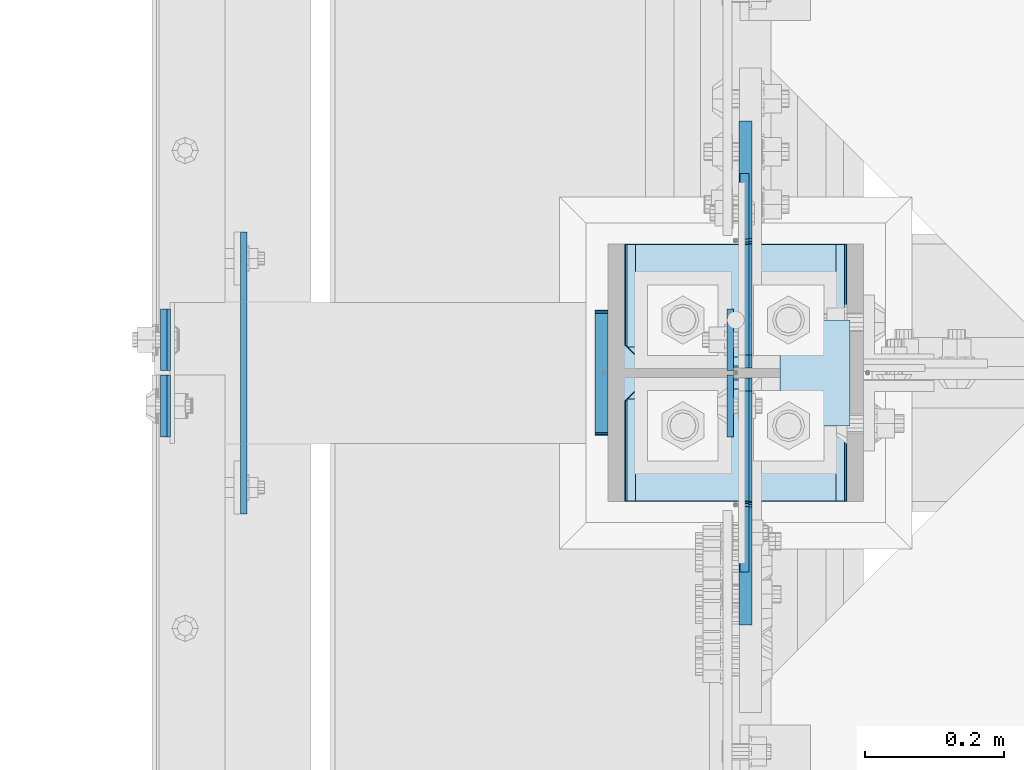
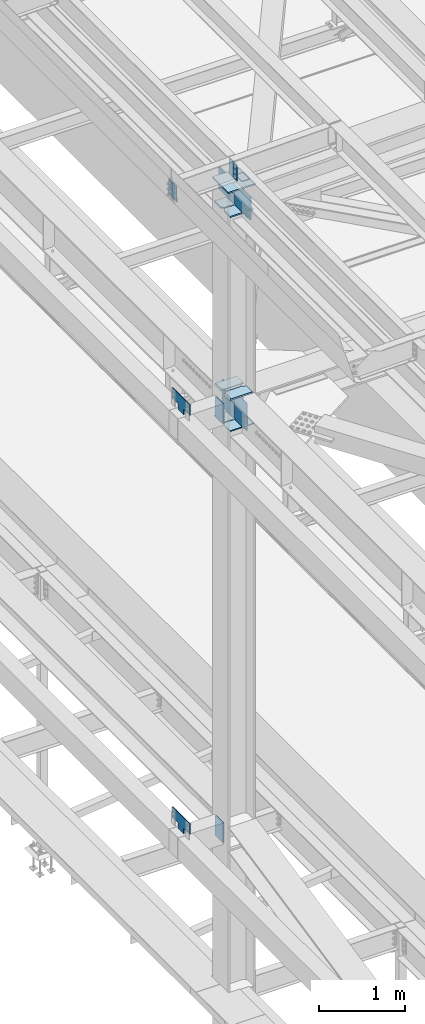
# One storey, part 3229 of 3843: 20 plates, 2 elements without a shape of their own.
"""IFC2X3 building model written with IfcOpenShell, lengths in millimetres."""

import ifcopenshell
import ifcopenshell.guid

model = None  # the IFC model being written
_history = None  # IfcOwnerHistory: only IFC2X3 demands one
_inside = {}  # id of a spatial element -> (the spatial element, [elements in it])
_under = {}  # id of a project, library or spatial element -> (it, [spatial elements below it])
_declared = {}  # id of a project -> (the project, [libraries it declares])
_typed = {}  # id of a type object -> (the type object, [elements of that type])
_made_of = {}  # id of a material, layer set ... -> (it, [elements and type objects made of it])


def new_model(schema):
    """Start an empty IFC model of exactly this schema.

    Asked for "IFC4X3", IfcOpenShell would pick the latest addendum, in which some entities
    have other attributes; the version numbers below select the first issue.
    IFC2X3 requires an IfcOwnerHistory on every rooted entity: one is made here for all.
    """
    global model, _history
    if schema == "IFC4X3":
        model = ifcopenshell.file(schema_version=(4, 3, 0, 0))
    else:
        model = ifcopenshell.file(schema=schema)
    _inside.clear()
    _under.clear()
    _declared.clear()
    _typed.clear()
    _made_of.clear()
    _history = None
    if model.schema == "IFC2X3":
        org = make("IfcOrganization", Name="unknown")
        user = make(
            "IfcPersonAndOrganization",
            ThePerson=make("IfcPerson", FamilyName="unknown"),
            TheOrganization=org,
        )
        app = make(
            "IfcApplication",
            ApplicationDeveloper=org,
            Version="unknown",
            ApplicationFullName="unknown",
            ApplicationIdentifier="unknown",
        )
        _history = make(
            "IfcOwnerHistory",
            OwningUser=user,
            OwningApplication=app,
            ChangeAction="ADDED",
            CreationDate=0,
        )
    return model


def make(cls, **values):
    """One entity of the class cls with the attributes given. An attribute that is None is left unset."""
    return model.create_entity(
        cls, **{name: value for name, value in values.items() if value is not None}
    )


def rooted(cls, **values):
    """An entity with a GlobalId (a new one), such as an element, a storey or a relation."""
    return make(cls, GlobalId=ifcopenshell.guid.new(), OwnerHistory=_history, **values)


def si_unit(unit_type, name, prefix=None):
    """IfcSIUnit, for example si_unit("LENGTHUNIT", "METRE", prefix="MILLI")."""
    return make("IfcSIUnit", UnitType=unit_type, Prefix=prefix, Name=name)


def assignment(units):
    """IfcUnitAssignment: the units of a project."""
    return None if units is None else make("IfcUnitAssignment", Units=units)


def point(xyz):
    """IfcCartesianPoint."""
    return None if xyz is None else make("IfcCartesianPoint", Coordinates=xyz)


def direction(xyz):
    """IfcDirection."""
    return None if xyz is None else make("IfcDirection", DirectionRatios=xyz)


def frame(location, z_axis=None, x_axis=None):
    """IfcAxis2Placement3D, a coordinate frame: its origin and axes. An axis left out is left unset."""
    return make(
        "IfcAxis2Placement3D",
        Location=point(location),
        Axis=direction(z_axis),
        RefDirection=direction(x_axis),
    )


def origin_with_axes():
    """The frame at (0, 0, 0) with the z axis (0, 0, 1) and the x axis (1, 0, 0) written out."""
    return frame((0.0, 0.0, 0.0), z_axis=(0.0, 0.0, 1.0), x_axis=(1.0, 0.0, 0.0))


def place(relative_to, where):
    """IfcLocalPlacement: puts the frame where relative to a parent placement (None: the world)."""
    return make(
        "IfcLocalPlacement", PlacementRelTo=relative_to, RelativePlacement=where
    )


def context(
    kind, dimensions, precision=None, world=None, true_north=None, identifier=None
):
    """IfcGeometricRepresentationContext, for example the 3D "Model" context."""
    return make(
        "IfcGeometricRepresentationContext",
        ContextIdentifier=identifier,
        ContextType=kind,
        CoordinateSpaceDimension=dimensions,
        Precision=precision,
        WorldCoordinateSystem=world,
        TrueNorth=true_north,
    )


def subcontext(parent, identifier, kind, view, scale=None):
    """IfcGeometricRepresentationSubContext, for example "Body" below "Model"."""
    return make(
        "IfcGeometricRepresentationSubContext",
        ContextIdentifier=identifier,
        ContextType=kind,
        ParentContext=parent,
        TargetScale=scale,
        TargetView=view,
    )


def project(units=None, contexts=None):
    """IfcProject with its units and contexts."""
    return rooted(
        "IfcProject",
        Name="project",
        RepresentationContexts=contexts,
        UnitsInContext=assignment(units),
    )


def spatial(cls, under=None, at=None, **own):
    """A site, building, storey or space (cls), placed at a placement, below another one or the project."""
    s = rooted(cls, ObjectPlacement=at, **own)
    if under is not None:
        _under.setdefault(under.id(), (under, []))[1].append(s)
    return s


def faces_of(points, faces, orient=None, outer=None):
    """IfcFace entities. A face is a list of loops; a loop is a list of indices into points, from 0.

    orient and outer hold one flag for each loop. By default every Orientation is true, the
    first loop of a face is its IfcFaceOuterBound and the others are IfcFaceBound.
    """
    made = []
    for i, loops in enumerate(faces):
        bounds = []
        for j, loop in enumerate(loops):
            is_outer = j == 0 if outer is None else outer[i][j]
            bounds.append(
                make(
                    "IfcFaceOuterBound" if is_outer else "IfcFaceBound",
                    Bound=make("IfcPolyLoop", Polygon=[points[k] for k in loop]),
                    Orientation=True if orient is None else orient[i][j],
                )
            )
        made.append(make("IfcFace", Bounds=bounds))
    return made


def faceted_brep(points, faces, orient=None, outer=None, voids=None):
    """IfcFacetedBrep: a solid bounded by flat faces; with voids (closed shells), ...WithVoids."""
    shared = [point(p) for p in points]
    hull = make("IfcClosedShell", CfsFaces=faces_of(shared, faces, orient, outer))
    if voids is None:
        return make("IfcFacetedBrep", Outer=hull)
    return make(
        "IfcFacetedBrepWithVoids",
        Outer=hull,
        Voids=[
            make(cls, CfsFaces=faces_of(shared, fs, o, b)) for cls, fs, o, b in voids
        ],
    )


def shape(context_of_items, identifier, shape_type, items):
    """IfcShapeRepresentation: the items that make up one representation, for example the "Body"."""
    return make(
        "IfcShapeRepresentation",
        ContextOfItems=context_of_items,
        RepresentationIdentifier=identifier,
        RepresentationType=shape_type,
        Items=items,
    )


def material(Name=None, Category=None):
    """IfcMaterial."""
    return make("IfcMaterial", Name=Name, Category=Category)


def made_of(thing, what):
    """Note that an element or type object is made of a material, layer set ...; save() writes the relation."""
    if what is not None:
        _made_of.setdefault(what.id(), (what, []))[1].append(thing)
    return thing


def type_object(cls, material=None, **own):
    """A type object (cls), such as IfcWallType, which elements share."""
    return made_of(rooted(cls, **own), material)


def element(
    cls,
    number,
    at=None,
    inside=None,
    cuts=None,
    type_object=None,
    material=None,
    context=None,
    identifier="Body",
    shape_type=None,
    held_by="IfcProductDefinitionShape",
    body=None,
    shapes=None,
    **own,
):
    """One element of the class cls, such as IfcWall. Its Tag is "e" and its number.

    at: its placement. inside: the storey or other place that contains it. cuts: it is an
    opening in that element (IfcRelVoidsElement). A single representation is given by context,
    identifier, shape_type and body (its items); several are given by shapes. held_by: the class
    of the entity that holds the representations. save() writes the other relations.
    """
    e = rooted(cls, Tag="e%d" % number, ObjectPlacement=at, **own)
    if body is not None:
        shapes = [shape(context, identifier, shape_type, body)]
    if shapes is not None:
        e.Representation = make(held_by, Representations=shapes)
    if inside is not None:
        _inside.setdefault(inside.id(), (inside, []))[1].append(e)
    if cuts is not None:
        rooted(
            "IfcRelVoidsElement", RelatingBuildingElement=cuts, RelatedOpeningElement=e
        )
    if type_object is not None:
        _typed.setdefault(type_object.id(), (type_object, []))[1].append(e)
    return made_of(e, material)


def aggregate(whole, parts):
    """IfcRelAggregates: a whole, such as a stair, and the parts it consists of."""
    return rooted("IfcRelAggregates", RelatingObject=whole, RelatedObjects=parts)


def save(model, path):
    """Write the relations noted so far, then the file.

    IfcRelAggregates (storeys below a building ...), IfcRelContainedInSpatialStructure (elements
    in a storey), IfcRelDefinesByType, IfcRelAssociatesMaterial and IfcRelDeclares: one each for
    every whole, place, type object, material and project.
    """
    for whole, parts in _under.values():
        aggregate(whole, parts)
    for where, things in _inside.values():
        rooted(
            "IfcRelContainedInSpatialStructure",
            RelatedElements=things,
            RelatingStructure=where,
        )
    for kind, things in _typed.values():
        rooted("IfcRelDefinesByType", RelatedObjects=things, RelatingType=kind)
    for what, things in _made_of.values():
        rooted("IfcRelAssociatesMaterial", RelatedObjects=things, RelatingMaterial=what)
    for by, libraries in _declared.values():
        rooted("IfcRelDeclares", RelatingContext=by, RelatedDefinitions=libraries)
    model.write(path)


model = new_model("IFC2X3")

# Units and contexts
model_context = context("Model", 3, precision=1e-05, world=origin_with_axes())
body_context = subcontext(model_context, "Body", "Model", "MODEL_VIEW")
ifc_project = project(units=[si_unit("LENGTHUNIT", "METRE", prefix="MILLI"), si_unit("AREAUNIT", "SQUARE_METRE"), si_unit("VOLUMEUNIT", "CUBIC_METRE"), si_unit("MASSUNIT", "GRAM", prefix="KILO"), si_unit("TIMEUNIT", "SECOND"), si_unit("PLANEANGLEUNIT", "RADIAN"), si_unit("SOLIDANGLEUNIT", "STERADIAN"), si_unit("THERMODYNAMICTEMPERATUREUNIT", "DEGREE_CELSIUS"), si_unit("LUMINOUSINTENSITYUNIT", "LUMEN")], contexts=[model_context])

# Site, building, storey
site_placement = place(None, origin_with_axes())
site = spatial("IfcSite", under=ifc_project, at=site_placement, CompositionType="ELEMENT")
building_placement = place(site_placement, origin_with_axes())
building = spatial("IfcBuilding", under=site, at=building_placement, Name="Undefined", CompositionType="ELEMENT")
storey_placement = place(building_placement, origin_with_axes())
storey = spatial("IfcBuildingStorey", under=building, at=storey_placement, Name="Undefined", CompositionType="ELEMENT", Elevation=0.0)

# Assembly, plates
assembly_1_placement = place(storey_placement, origin_with_axes())
assembly_1 = element("IfcElementAssembly", 1, at=assembly_1_placement, inside=storey, Name="COLUMN", AssemblyPlace="NOTDEFINED", PredefinedType="RIGID_FRAME")
ifc_material = material(Name="STEEL/A572-50")
plate_type_1 = type_object("IfcPlateType", PredefinedType="NOTDEFINED")
plate_1_placement = place(assembly_1_placement, frame((36736.3375, 42387.04375, 42011.6), z_axis=(-1.0, 0.0, 0.0), x_axis=(0.0, -1.0, 0.0)))
plate_1 = element("IfcPlate", 2, at=plate_1_placement, type_object=plate_type_1, material=ifc_material, Name="PLATE", context=body_context, shape_type="Brep", body=[
    faceted_brep([(0.0, -6.3499999046162, 0.0), (0.0, -6.34999999999854, 320.674987792969), (0.0, 6.34999999999854, 320.674987792969), (7.27595761418343e-12, 6.3499999046162, 0.0), (144.462501525879, -6.34999999999854, 320.674987792969), (144.462501525879, 6.34999999999854, 320.674987792969), (177.800003051758, -6.34999999999854, 287.33748626709), (177.800003051758, 6.34999999999854, 287.33748626709), (177.800003051758, -6.34999999999854, 33.3375015258789), (177.800003051758, 6.34999999999854, 33.3375015258789), (144.462501525879, -6.34999999999854, 0.0), (144.462501525879, 6.34999999999854, 0.0)], [[[0, 1, 2, 3]], [[1, 4, 5, 2]], [[4, 6, 7, 5]], [[6, 8, 9, 7]], [[8, 10, 11, 9]], [[10, 0, 3, 11]], [[5, 7, 9, 11, 3, 2]], [[10, 8, 6, 4, 1, 0]]]),
])
plate_2_placement = place(assembly_1_placement, frame((36736.3375, 42194.95625, 42011.6), z_axis=(-1.0, 0.0, 0.0), x_axis=(0.0, -1.0, 0.0)))
plate_2 = element("IfcPlate", 3, at=plate_2_placement, type_object=plate_type_1, material=ifc_material, Name="PLATE", context=body_context, shape_type="Brep", body=[
    faceted_brep([(0.0, -6.34999999999854, 33.3375015258789), (0.0, -6.34999999999854, 287.33748626709), (0.0, 6.34999999999854, 287.33748626709), (0.0, 6.34999999999854, 33.3375015258789), (33.3375015258789, -6.34999999999854, 320.674987792969), (33.3375015258789, 6.34999999999854, 320.674987792969), (177.800003051758, -6.34999999999854, 320.674987792969), (177.800003051758, 6.34999999999854, 320.674987792969), (177.800000000003, -6.34999999999854, 0.0), (177.800000000003, 6.34999999999854, 0.0), (33.3375015258789, -6.34999999999854, 0.0), (33.3375015258789, 6.34999999999854, 0.0)], [[[0, 1, 2, 3]], [[1, 4, 5, 2]], [[4, 6, 7, 5]], [[6, 8, 9, 7]], [[8, 10, 11, 9]], [[10, 0, 3, 11]], [[5, 7, 9, 11, 3, 2]], [[10, 8, 6, 4, 1, 0]]]),
])

assembly_2_placement = place(storey_placement, origin_with_axes())
assembly_2 = element("IfcElementAssembly", 4, at=assembly_2_placement, inside=storey, Name="BEAM", AssemblyPlace="NOTDEFINED", PredefinedType="RIGID_FRAME")
plate_type_2 = type_object("IfcPlateType", PredefinedType="NOTDEFINED")
plate_3_placement = place(assembly_2_placement, frame((36568.0624999353, 42205.275, 45691.4946293693), z_axis=(0.0, 1.0, 0.0), x_axis=(0.0, 0.0, -1.0)))
plate_3 = element("IfcPlate", 5, at=plate_3_placement, type_object=plate_type_2, material=ifc_material, Name="PLATE", context=body_context, shape_type="Brep", body=[
    faceted_brep([(0.0, -4.76249999999709, 0.0), (0.0, -4.76249999999709, 88.9000015258789), (0.0, 4.76249999999709, 88.9000015258789), (0.0, 4.76249999999709, 0.0), (228.600006102781, -4.7625000004191, 88.9000015257589), (228.600006102781, 4.76249999954598, 88.9000015257443), (228.600006103079, -4.7625000004482, 7.27595761418343e-12), (228.600006103079, 4.76249999954598, -7.27595761418343e-12)], [[[0, 1, 2, 3]], [[1, 4, 5, 2]], [[4, 6, 7, 5]], [[6, 0, 3, 7]], [[5, 7, 3, 2]], [[6, 4, 1, 0]]]),
])
plate_4_placement = place(assembly_2_placement, frame((36568.0624999295, 42198.925, 45691.4946293693), z_axis=(0.0, -1.0, 0.0), x_axis=(0.0, 0.0, -1.0)))
plate_4 = element("IfcPlate", 6, at=plate_4_placement, type_object=plate_type_2, material=ifc_material, Name="PLATE", context=body_context, shape_type="Brep", body=[
    faceted_brep([(0.0, -4.76249999999709, 0.0), (0.0, -4.76249999999709, 88.9000015258789), (0.0, 4.76249999999709, 88.9000015258789), (0.0, 4.76249999999709, 0.0), (228.600006102781, -4.7625000004191, 88.9000015257589), (228.600006102781, 4.76249999954598, 88.9000015257443), (228.600006103079, -4.7625000004482, 7.27595761418343e-12), (228.600006103079, 4.76249999954598, -7.27595761418343e-12)], [[[0, 1, 2, 3]], [[1, 4, 5, 2]], [[4, 6, 7, 5]], [[6, 0, 3, 7]], [[5, 7, 3, 2]], [[6, 4, 1, 0]]]),
])
plate_5_placement = place(assembly_2_placement, frame((35751.3030534853, 42198.925, 45674.0381290243), z_axis=(0.0, -1.0, 0.0), x_axis=(0.0211520550054438, 0.0, -0.999776270257025)))
plate_5 = element("IfcPlate", 7, at=plate_5_placement, type_object=plate_type_2, material=ifc_material, Name="PLATE", context=body_context, shape_type="Brep", body=[
    faceted_brep([(0.0, -4.76249999999709, 0.0), (0.0, -4.76249999999709, 88.9000015258789), (0.0, 4.76249999999709, 88.9000015258789), (0.0, 4.76249999999709, 0.0), (228.600006102781, -4.7625000004191, 88.9000015257589), (228.600006102781, 4.76249999954598, 88.9000015257443), (228.600006103079, -4.7625000004482, 7.27595761418343e-12), (228.600006103079, 4.76249999954598, -7.27595761418343e-12)], [[[0, 1, 2, 3]], [[1, 4, 5, 2]], [[4, 6, 7, 5]], [[6, 0, 3, 7]], [[5, 7, 3, 2]], [[6, 4, 1, 0]]]),
])
plate_6_placement = place(assembly_2_placement, frame((35751.3030534967, 42205.275, 45674.0381290353), z_axis=(0.0, 1.0, 0.0), x_axis=(0.0211520550054438, 0.0, -0.999776270257025)))
plate_6 = element("IfcPlate", 8, at=plate_6_placement, type_object=plate_type_2, material=ifc_material, Name="PLATE", context=body_context, shape_type="Brep", body=[
    faceted_brep([(0.0, -4.76249999999709, 0.0), (0.0, -4.76249999999709, 88.9000015258789), (0.0, 4.76249999999709, 88.9000015258789), (0.0, 4.76249999999709, 0.0), (228.600006102781, -4.7625000004191, 88.9000015257589), (228.600006102781, 4.76249999954598, 88.9000015257443), (228.600006103079, -4.7625000004482, 7.27595761418343e-12), (228.600006103079, 4.76249999954598, -7.27595761418343e-12)], [[[0, 1, 2, 3]], [[1, 4, 5, 2]], [[4, 6, 7, 5]], [[6, 0, 3, 7]], [[5, 7, 3, 2]], [[6, 4, 1, 0]]]),
])
aggregate(assembly_2, [plate_3, plate_4, plate_5, plate_6])

# Plate
plate_type_3 = type_object("IfcPlateType", PredefinedType="NOTDEFINED")
plate_7_placement = place(assembly_1_placement, frame((36639.5, 42278.3000000002, 45422.542188), z_axis=(1.0, 0.0, 0.0), x_axis=(0.0, -1.0, 0.0)))
plate_7 = element("IfcPlate", 9, at=plate_7_placement, type_object=plate_type_3, material=ifc_material, Name="PLATE", context=body_context, shape_type="Brep", body=[
    faceted_brep([(0.0, -3.17499999999927, 0.0), (0.0, -3.17499999999927, 101.600000000006), (0.0, 3.17499999999927, 101.600000000006), (0.0, 3.17499999999927, 0.0), (152.399998474109, -3.17500000000291, 101.599998474121), (152.399998474109, 3.17500000000291, 101.599998474121), (152.399998474109, -3.17500000000291, 0.0), (152.399998474109, 3.17500000000291, 0.0)], [[[0, 1, 2, 3]], [[1, 4, 5, 2]], [[4, 6, 7, 5]], [[6, 0, 3, 7]], [[5, 7, 3, 2]], [[6, 4, 1, 0]]]),
])

plate_type_4 = type_object("IfcPlateType", PredefinedType="NOTDEFINED")
plate_8_placement = place(assembly_1_placement, frame((36415.6625, 42209.24375, 42457.6875), z_axis=(1.0, 0.0, 0.0), x_axis=(0.0, 1.0, 0.0)))
plate_8 = element("IfcPlate", 10, at=plate_8_placement, type_object=plate_type_4, material=ifc_material, Name="PLATE", context=body_context, shape_type="Brep", body=[
    faceted_brep([(16.0071099052875, 11.1125000000029, 269.995628805875), (16.0071099052875, 11.1125000000029, 50.6793589870867), (9.32072521071677, -0.46891855342983, 54.0862421540805), (3.17549995230365, -11.1125000000029, 55.0595502173019), (3.17549995230365, -11.1125000000029, 265.615437575667), (9.32072521071677, -0.46891855342983, 266.588745638888), (177.800003051758, 11.1125000000029, 16.0061099052982), (177.800003051758, -11.1125000000029, 3.17449995231436), (30.1625003814697, -11.1125000000029, 3.17449995231436), (30.1625003814697, 11.1125000000029, 16.0061099052982), (30.1625003814697, 11.1125000000029, 304.667890094701), (30.1625003814697, -11.1125000000029, 317.499500047685), (177.800003051758, -11.1125000000029, 317.499500047685), (177.800003051758, 11.1125000000029, 304.667890094701), (9.32072521071677, -11.1125000000029, 266.588745638888), (17.7290728964945, -11.1125000000029, 270.873012772987), (17.7290728964945, 11.1125000000029, 270.873012772987), (24.4019754014516, -11.1125000000029, 277.545915277944), (24.4019754014516, 11.1125000000029, 277.545915277944), (28.6862425355503, -11.1125000000029, 285.954262963722), (28.6862425355503, 11.1125000000029, 285.954262963722), (30.1625003814697, -11.1125000000029, 295.274988174438), (30.1625003814697, 11.1125000000029, 295.274988174438), (30.1625003814697, -11.1125000000029, 25.3999996185303), (30.1625003814697, 11.1125000000029, 25.3999996185303), (28.6862425355503, -11.1125000000029, 34.720724829247), (28.6862425355503, 11.1125000000029, 34.720724829247), (24.4019754014516, -11.1125000000029, 43.1290725150247), (24.4019754014516, 11.1125000000029, 43.1290725150247), (17.7290728964945, -11.1125000000029, 49.8019750199819), (17.7290728964945, 11.1125000000029, 49.8019750199819), (9.32072521071677, -11.1125000000029, 54.0862421540805)], [[[0, 1, 2, 3, 4, 5]], [[6, 7, 8, 9]], [[10, 11, 12, 13]], [[14, 5, 4]], [[14, 15, 16, 0, 5]], [[15, 17, 18, 16]], [[17, 19, 20, 18]], [[19, 21, 22, 20]], [[22, 21, 11, 10]], [[13, 12, 7, 6]], [[23, 24, 9, 8]], [[23, 25, 26, 24]], [[25, 27, 28, 26]], [[27, 29, 30, 28]], [[30, 29, 31, 2, 1]], [[31, 3, 2]], [[16, 18, 20, 22, 10, 13, 6, 9, 24, 26, 28, 30, 1, 0]], [[31, 29, 27, 25, 23, 8, 7, 12, 11, 21, 19, 17, 15, 14, 4, 3]]]),
])

plate_9_placement = place(assembly_1_placement, frame((36415.6625, 42017.15625, 42457.6875), z_axis=(1.0, 0.0, 0.0), x_axis=(0.0, 1.0, 0.0)))
plate_9 = element("IfcPlate", 11, at=plate_9_placement, type_object=plate_type_4, material=ifc_material, Name="PLATE", context=body_context, shape_type="Brep", body=[
    faceted_brep([(161.793390094688, 11.1125000000029, 50.6796121948501), (161.793390094688, 11.1125000000029, 269.995375598119), (168.479277841041, -0.468057794503693, 266.588745638888), (174.625000047672, -11.1125000000029, 265.615358866802), (174.625000047672, -11.1125000000029, 55.0596289261666), (168.479277841041, -0.468057794503693, 54.0862421540805), (147.637502670288, 11.1125000000029, 16.0061099052982), (147.637502670288, -11.1125000000029, 3.17449995231436), (0.0, -11.1125000000029, 3.17449995231436), (0.0, 11.1125000000029, 16.0061099052982), (0.0, 11.1125000000029, 304.667890094701), (0.0, -11.1125000000029, 317.499500047685), (147.637502670288, -11.1125000000029, 317.499500047685), (147.637502670288, 11.1125000000029, 304.667890094701), (147.637502670288, -11.1125000000029, 295.274988174438), (147.637502670288, 11.1125000000029, 295.274988174438), (149.113760516208, -11.1125000000029, 285.954262963722), (149.113760516208, 11.1125000000029, 285.954262963722), (153.398027650306, -11.1125000000029, 277.545915277944), (153.398027650306, 11.1125000000029, 277.545915277944), (160.070930155263, -11.1125000000029, 270.873012772987), (160.070930155263, 11.1125000000029, 270.873012772987), (168.479277841041, -11.1125000000029, 266.588745638888), (168.479277841041, -11.1125000000029, 54.0862421540805), (160.070930155263, -11.1125000000029, 49.8019750199819), (160.070930155263, 11.1125000000029, 49.8019750199819), (153.398027650306, -11.1125000000029, 43.1290725150247), (153.398027650306, 11.1125000000029, 43.1290725150247), (149.113760516208, -11.1125000000029, 34.720724829247), (149.113760516208, 11.1125000000029, 34.720724829247), (147.637502670288, -11.1125000000029, 25.3999996185303), (147.637502670288, 11.1125000000029, 25.3999996185303)], [[[0, 1, 2, 3, 4, 5]], [[6, 7, 8, 9]], [[10, 11, 12, 13]], [[11, 10, 9, 8]], [[14, 15, 13, 12]], [[14, 16, 17, 15]], [[16, 18, 19, 17]], [[18, 20, 21, 19]], [[21, 20, 22, 2, 1]], [[22, 3, 2]], [[23, 5, 4]], [[23, 24, 25, 0, 5]], [[24, 26, 27, 25]], [[26, 28, 29, 27]], [[28, 30, 31, 29]], [[31, 30, 7, 6]], [[25, 27, 29, 31, 6, 9, 10, 13, 15, 17, 19, 21, 1, 0]], [[7, 30, 28, 26, 24, 23, 4, 3, 22, 20, 18, 16, 14, 12, 11, 8]]]),
])

plate_type_5 = type_object("IfcPlateType", PredefinedType="NOTDEFINED")
plate_10_placement = place(assembly_1_placement, frame((36734.75, 42387.04375, 45059.5999999993), z_axis=(-1.0, 0.0, 0.0), x_axis=(0.0, -1.0, 0.0)))
plate_10 = element("IfcPlate", 12, at=plate_10_placement, type_object=plate_type_5, material=ifc_material, Name="PLATE", context=body_context, shape_type="Brep", body=[
    faceted_brep([(0.0, -9.52500000000146, 0.0), (0.0, -9.52500000000146, 317.5), (0.0, 9.52500000000146, 317.5), (0.0, 9.52500000000146, 0.0), (144.462501525879, -9.52500000000146, 317.5), (144.462501525879, 9.52500000000146, 317.5), (177.800003051758, -9.52500000000146, 284.162498474121), (177.800003051758, 9.52500000000146, 284.162498474121), (177.800003051758, -9.52500000000146, 33.3375015258789), (177.800003051758, 9.52500000000146, 33.3375015258789), (144.462501525879, -9.52500000000146, 0.0), (144.462501525879, 9.52500000000146, 0.0)], [[[0, 1, 2, 3]], [[1, 4, 5, 2]], [[4, 6, 7, 5]], [[6, 8, 9, 7]], [[8, 10, 11, 9]], [[10, 0, 3, 11]], [[5, 7, 9, 11, 3, 2]], [[10, 8, 6, 4, 1, 0]]]),
])

plate_11_placement = place(assembly_1_placement, frame((36417.25, 42017.15625, 45059.5999999878), z_axis=(1.0, 0.0, 0.0), x_axis=(0.0, 1.0, 0.0)))
plate_11 = element("IfcPlate", 13, at=plate_11_placement, type_object=plate_type_5, material=ifc_material, Name="PLATE", context=body_context, shape_type="Brep", body=[
    faceted_brep([(0.0, -9.52500000000146, 0.0), (0.0, -9.52500000000146, 317.5), (0.0, 9.52500000000146, 317.5), (0.0, 9.52500000000146, 0.0), (144.462501525879, -9.52500000000146, 317.5), (144.462501525879, 9.52500000000146, 317.5), (177.800003051758, -9.52500000000146, 284.162498474121), (177.800003051758, 9.52500000000146, 284.162498474121), (177.800003051758, -9.52500000000146, 33.3375015258789), (177.800003051758, 9.52500000000146, 33.3375015258789), (144.462501525879, -9.52500000000146, 0.0), (144.462501525879, 9.52500000000146, 0.0)], [[[0, 1, 2, 3]], [[1, 4, 5, 2]], [[4, 6, 7, 5]], [[6, 8, 9, 7]], [[8, 10, 11, 9]], [[10, 0, 3, 11]], [[5, 7, 9, 11, 3, 2]], [[10, 8, 6, 4, 1, 0]]]),
])

plate_type_6 = type_object("IfcPlateType", PredefinedType="NOTDEFINED")
plate_12_placement = place(assembly_1_placement, frame((35866.3875, 42265.6, 36404.55), z_axis=(0.0, 0.0, 1.0), x_axis=(0.0, -1.0, 0.0)))
plate_12 = element("IfcPlate", 14, at=plate_12_placement, type_object=plate_type_6, material=ifc_material, Name="PLATE", context=body_context, shape_type="Brep", body=[
    faceted_brep([(0.0, -4.76249999999709, 0.0), (-3.49245965480804e-10, -4.76249999999709, 76.1999999999462), (-3.49245965480804e-10, 4.76249999999709, 76.1999999999462), (0.0, 4.76249999999709, 0.0), (-139.699996948242, -4.76249999999709, 76.1999969482422), (-139.699996948242, 4.76249999999709, 76.1999969482422), (-139.699996948242, -4.76249999999709, 228.600006103516), (-139.699996948242, 4.76249999999709, 228.600006103516), (266.700012207031, -4.76249999999709, 228.600006103516), (266.700012207031, 4.76249999999709, 228.600006103516), (266.700012207031, -4.76249999999709, 76.1999969482422), (266.700012207031, 4.76249999999709, 76.1999969482422), (126.999992370605, -4.76249999999709, 76.1999969482422), (126.999992370605, 4.76249999999709, 76.1999969482422), (126.999992370605, -4.76249999999709, 0.0), (126.999992370605, 4.76249999999709, 0.0)], [[[0, 1, 2, 3]], [[1, 4, 5, 2]], [[4, 6, 7, 5]], [[6, 8, 9, 7]], [[8, 10, 11, 9]], [[10, 12, 13, 11]], [[12, 14, 15, 13]], [[14, 0, 3, 15]], [[5, 7, 9, 11, 13, 15, 3, 2]], [[14, 12, 10, 8, 6, 4, 1, 0]]]),
])

plate_13_placement = place(assembly_1_placement, frame((35866.3875, 42265.6, 42367.2), z_axis=(0.0, 0.0, 1.0), x_axis=(0.0, -1.0, 0.0)))
plate_13 = element("IfcPlate", 15, at=plate_13_placement, type_object=plate_type_6, material=ifc_material, Name="PLATE", context=body_context, shape_type="Brep", body=[
    faceted_brep([(0.0, -4.76249999999709, 0.0), (-3.49245965480804e-10, -4.76249999999709, 76.1999999999462), (-3.49245965480804e-10, 4.76249999999709, 76.1999999999462), (0.0, 4.76249999999709, 0.0), (-139.699996948242, -4.76249999999709, 76.1999969482422), (-139.699996948242, 4.76249999999709, 76.1999969482422), (-139.699996948242, -4.76249999999709, 228.600006103516), (-139.699996948242, 4.76249999999709, 228.600006103516), (266.700012207031, -4.76249999999709, 228.600006103516), (266.700012207031, 4.76249999999709, 228.600006103516), (266.700012207031, -4.76249999999709, 76.1999969482422), (266.700012207031, 4.76249999999709, 76.1999969482422), (126.999992370605, -4.76249999999709, 76.1999969482422), (126.999992370605, 4.76249999999709, 76.1999969482422), (126.999992370605, -4.76249999999709, 0.0), (126.999992370605, 4.76249999999709, 0.0)], [[[0, 1, 2, 3]], [[1, 4, 5, 2]], [[4, 6, 7, 5]], [[6, 8, 9, 7]], [[8, 10, 11, 9]], [[10, 12, 13, 11]], [[12, 14, 15, 13]], [[14, 0, 3, 15]], [[5, 7, 9, 11, 13, 15, 3, 2]], [[14, 12, 10, 8, 6, 4, 1, 0]]]),
])

plate_type_7 = type_object("IfcPlateType", PredefinedType="NOTDEFINED")
plate_14_placement = place(assembly_1_placement, frame((36382.325, 42111.6125, 42356.4551879883), z_axis=(0.0, 1.0, 0.0), x_axis=(0.0, 0.0, -1.0)))
plate_14 = element("IfcPlate", 16, at=plate_14_placement, type_object=plate_type_7, material=ifc_material, Name="PLATE", context=body_context, shape_type="Brep", body=[
    faceted_brep([(-8.22591685395256e-13, -9.52499999999854, 7.9375), (0.0, -9.52499999999418, 173.037499999991), (0.0, 9.52499999999418, 173.037499999991), (0.0, 9.52499999999418, 7.9375), (0.604206210693519, -9.52499999999418, 176.075049744395), (0.604206210693519, 9.52499999999418, 176.075049744395), (2.32483992433117, -9.52499999999418, 178.65016007566), (2.32483992433117, 9.52499999999418, 178.65016007566), (4.89995025560347, -9.52499999999418, 180.370793789305), (4.89995025560347, 9.52499999999418, 180.370793789305), (7.9375, -9.52499999999418, 180.974999999991), (7.9375, 9.52499999999418, 180.974999999991), (274.637499999997, -9.52499999999418, 180.974999999991), (274.637499999997, 9.52499999999418, 180.974999999991), (277.675049744394, -9.52499999999418, 180.370793789305), (277.675049744394, 9.52499999999418, 180.370793789305), (280.250160075666, -9.52499999999418, 178.65016007566), (280.250160075666, 9.52499999999418, 178.65016007566), (281.970793789304, -9.52499999999418, 176.075049744395), (281.970793789304, 9.52499999999418, 176.075049744395), (282.574999999997, -9.52499999999418, 173.037499999991), (282.574999999997, 9.52499999999418, 173.037499999991), (282.574999999997, -9.52499999999418, 7.9375), (282.574999999997, 9.52499999999418, 7.9375), (281.970793789304, -9.52499999999418, 4.8999502555962), (281.970793789304, 9.52499999999418, 4.8999502555962), (280.250160075666, -9.52499999999418, 2.32483992433117), (280.250160075666, 9.52499999999418, 2.32483992433117), (277.675049744394, -9.52499999999418, 0.604206210686243), (277.675049744394, 9.52499999999418, 0.604206210686243), (274.637499999997, -9.52499999999418, 0.0), (274.637499999997, 9.52499999999418, 0.0), (7.9375, -9.52499999999854, 0.0), (7.9375, 9.52499999999418, 0.0), (4.8999502555962, -9.52499999999418, 0.604206210693519), (4.8999502555962, 9.52499999999418, 0.604206210693519), (2.32483992433117, -9.52499999999418, 2.32483992433117), (2.32483992433117, 9.52499999999418, 2.32483992433117), (0.604206210686243, -9.52499999999418, 4.89995025560347), (0.604206210686243, 9.52499999999418, 4.89995025560347)], [[[0, 1, 2, 3]], [[1, 4, 5, 2]], [[4, 6, 7, 5]], [[6, 8, 9, 7]], [[8, 10, 11, 9]], [[10, 12, 13, 11]], [[12, 14, 15, 13]], [[14, 16, 17, 15]], [[16, 18, 19, 17]], [[18, 20, 21, 19]], [[20, 22, 23, 21]], [[22, 24, 25, 23]], [[24, 26, 27, 25]], [[26, 28, 29, 27]], [[28, 30, 31, 29]], [[30, 32, 33, 31]], [[32, 34, 35, 33]], [[34, 36, 37, 35]], [[36, 38, 39, 37]], [[38, 0, 3, 39]], [[5, 7, 9, 11, 13, 15, 17, 19, 21, 23, 25, 27, 29, 31, 33, 35, 37, 39, 3, 2]], [[38, 36, 34, 32, 30, 28, 26, 24, 22, 20, 18, 16, 14, 12, 10, 8, 6, 4, 1, 0]]]),
])

plate_15_placement = place(assembly_1_placement, frame((36382.325, 42111.6125, 36393.4375), z_axis=(0.0, 1.0, 0.0), x_axis=(0.0, 0.0, -1.0)))
plate_15 = element("IfcPlate", 17, at=plate_15_placement, type_object=plate_type_7, material=ifc_material, Name="PLATE", context=body_context, shape_type="Brep", body=[
    faceted_brep([(-8.22591685395256e-13, -9.52499999999854, 7.9375), (0.0, -9.52499999999418, 173.037499999991), (0.0, 9.52499999999418, 173.037499999991), (0.0, 9.52499999999418, 7.9375), (0.604206210693519, -9.52499999999418, 176.075049744395), (0.604206210693519, 9.52499999999418, 176.075049744395), (2.32483992433117, -9.52499999999418, 178.65016007566), (2.32483992433117, 9.52499999999418, 178.65016007566), (4.89995025560347, -9.52499999999418, 180.370793789305), (4.89995025560347, 9.52499999999418, 180.370793789305), (7.9375, -9.52499999999418, 180.974999999991), (7.9375, 9.52499999999418, 180.974999999991), (274.637499999997, -9.52499999999418, 180.974999999991), (274.637499999997, 9.52499999999418, 180.974999999991), (277.675049744394, -9.52499999999418, 180.370793789305), (277.675049744394, 9.52499999999418, 180.370793789305), (280.250160075666, -9.52499999999418, 178.65016007566), (280.250160075666, 9.52499999999418, 178.65016007566), (281.970793789304, -9.52499999999418, 176.075049744395), (281.970793789304, 9.52499999999418, 176.075049744395), (282.574999999997, -9.52499999999418, 173.037499999991), (282.574999999997, 9.52499999999418, 173.037499999991), (282.574999999997, -9.52499999999418, 7.9375), (282.574999999997, 9.52499999999418, 7.9375), (281.970793789304, -9.52499999999418, 4.8999502555962), (281.970793789304, 9.52499999999418, 4.8999502555962), (280.250160075666, -9.52499999999418, 2.32483992433117), (280.250160075666, 9.52499999999418, 2.32483992433117), (277.675049744394, -9.52499999999418, 0.604206210686243), (277.675049744394, 9.52499999999418, 0.604206210686243), (274.637499999997, -9.52499999999418, 0.0), (274.637499999997, 9.52499999999418, 0.0), (7.9375, -9.52499999999854, 0.0), (7.9375, 9.52499999999418, 0.0), (4.8999502555962, -9.52499999999418, 0.604206210693519), (4.8999502555962, 9.52499999999418, 0.604206210693519), (2.32483992433117, -9.52499999999418, 2.32483992433117), (2.32483992433117, 9.52499999999418, 2.32483992433117), (0.604206210686243, -9.52499999999418, 4.89995025560347), (0.604206210686243, 9.52499999999418, 4.89995025560347)], [[[0, 1, 2, 3]], [[1, 4, 5, 2]], [[4, 6, 7, 5]], [[6, 8, 9, 7]], [[8, 10, 11, 9]], [[10, 12, 13, 11]], [[12, 14, 15, 13]], [[14, 16, 17, 15]], [[16, 18, 19, 17]], [[18, 20, 21, 19]], [[20, 22, 23, 21]], [[22, 24, 25, 23]], [[24, 26, 27, 25]], [[26, 28, 29, 27]], [[28, 30, 31, 29]], [[30, 32, 33, 31]], [[32, 34, 35, 33]], [[34, 36, 37, 35]], [[36, 38, 39, 37]], [[38, 0, 3, 39]], [[5, 7, 9, 11, 13, 15, 17, 19, 21, 23, 25, 27, 29, 31, 33, 35, 37, 39, 3, 2]], [[38, 36, 34, 32, 30, 28, 26, 24, 22, 20, 18, 16, 14, 12, 10, 8, 6, 4, 1, 0]]]),
])

plate_type_8 = type_object("IfcPlateType", PredefinedType="NOTDEFINED")
plate_16_placement = place(assembly_1_placement, frame((36588.7000000954, 42209.24375, 42037.0), z_axis=(0.0, 0.707106781186548, 0.707106781186548), x_axis=(5.70000238222118e-08, 0.707106781186546, -0.707106781186546)))
plate_16 = element("IfcPlate", 18, at=plate_16_placement, type_object=plate_type_8, material=ifc_material, Name="PLATE", context=body_context, shape_type="Brep", body=[
    faceted_brep([(0.0, -6.3499999046162, 0.0), (-276.142875721547, -6.34999999999854, 276.14287572154), (-276.142875721547, 6.34999999999854, 276.14287572154), (7.27595761418343e-12, 6.3499999046162, 0.0), (-276.142875721554, -6.34999999999854, 303.083644084625), (-276.142875721554, 6.34999999999854, 303.083644084625), (-163.889674208724, -6.34999999999854, 415.336845597456), (-163.889674208724, 6.34999999999854, 415.336845597456), (-148.174225862076, -6.34999999999854, 399.621397250812), (-148.174225862076, 6.34999999999854, 399.621397250812), (-144.054049393933, -6.34999999999854, 396.868383350338), (-144.054049393933, 6.34999999999854, 396.868383350338), (-139.193969875902, -6.34999999999854, 395.901653427747), (-139.193969875902, 6.34999999999854, 395.901653427747), (-134.33389035787, -6.34999999999854, 396.868383350338), (-134.33389035787, 6.34999999999854, 396.868383350338), (-130.213713889723, -6.34999999999854, 399.621397250805), (-130.213713889723, 6.34999999999854, 399.621397250805), (-66.7906549001309, -6.34999999999854, 463.044456240401), (-66.7906549001309, 6.34999999999854, 463.044456240401), (211.597284851669, -6.34999999999854, 184.656516488598), (211.597284851669, 6.34999999999854, 184.656516488598), (26.9407683632217, -6.34999999999854, 1.30967237055302e-10), (26.9407683632217, 6.34999999999854, 1.30967237055302e-10)], [[[0, 1, 2, 3]], [[1, 4, 5, 2]], [[4, 6, 7, 5]], [[6, 8, 9, 7]], [[8, 10, 11, 9]], [[10, 12, 13, 11]], [[12, 14, 15, 13]], [[14, 16, 17, 15]], [[16, 18, 19, 17]], [[18, 20, 21, 19]], [[20, 22, 23, 21]], [[22, 0, 3, 23]], [[5, 7, 9, 11, 13, 15, 17, 19, 21, 23, 3, 2]], [[22, 20, 18, 16, 14, 12, 10, 8, 6, 4, 1, 0]]]),
])

plate_17_placement = place(assembly_1_placement, frame((36588.7000000954, 42194.95625, 42037.0), z_axis=(0.0, -0.707106781186682, 0.707106781186413), x_axis=(0.0, -0.707106781186548, -0.707106781186548)))
plate_17 = element("IfcPlate", 19, at=plate_17_placement, type_object=plate_type_8, material=ifc_material, Name="PLATE", context=body_context, shape_type="Brep", body=[
    faceted_brep([(0.0, -6.3499999046162, 0.0), (-276.142875721547, -6.34999999999854, 276.14287572154), (-276.142875721547, 6.34999999999854, 276.14287572154), (7.27595761418343e-12, 6.3499999046162, 0.0), (-276.142875721554, -6.34999999999854, 303.083644084625), (-276.142875721554, 6.34999999999854, 303.083644084625), (-163.889674208724, -6.34999999999854, 415.336845597456), (-163.889674208724, 6.34999999999854, 415.336845597456), (-148.174225862076, -6.34999999999854, 399.621397250812), (-148.174225862076, 6.34999999999854, 399.621397250812), (-144.054049393933, -6.34999999999854, 396.868383350338), (-144.054049393933, 6.34999999999854, 396.868383350338), (-139.193969875902, -6.34999999999854, 395.901653427747), (-139.193969875902, 6.34999999999854, 395.901653427747), (-134.33389035787, -6.34999999999854, 396.868383350338), (-134.33389035787, 6.34999999999854, 396.868383350338), (-130.213713889723, -6.34999999999854, 399.621397250805), (-130.213713889723, 6.34999999999854, 399.621397250805), (-66.7906549001309, -6.34999999999854, 463.044456240401), (-66.7906549001309, 6.34999999999854, 463.044456240401), (211.597284851669, -6.34999999999854, 184.656516488598), (211.597284851669, 6.34999999999854, 184.656516488598), (26.9407683632217, -6.34999999999854, 1.30967237055302e-10), (26.9407683632217, 6.34999999999854, 1.30967237055302e-10)], [[[0, 1, 2, 3]], [[1, 4, 5, 2]], [[4, 6, 7, 5]], [[6, 8, 9, 7]], [[8, 10, 11, 9]], [[10, 12, 13, 11]], [[12, 14, 15, 13]], [[14, 16, 17, 15]], [[16, 18, 19, 17]], [[18, 20, 21, 19]], [[20, 22, 23, 21]], [[22, 0, 3, 23]], [[5, 7, 9, 11, 13, 15, 17, 19, 21, 23, 3, 2]], [[22, 20, 18, 16, 14, 12, 10, 8, 6, 4, 1, 0]]]),
])

plate_type_9 = type_object("IfcPlateType", PredefinedType="NOTDEFINED")
plate_18_placement = place(assembly_1_placement, frame((36590.2875004045, 42209.24375, 45088.1750026615), z_axis=(0.0, 0.707106781186548, 0.707106781186548), x_axis=(5.70000238222118e-08, 0.707106781186546, -0.707106781186546)))
plate_18 = element("IfcPlate", 20, at=plate_18_placement, type_object=plate_type_9, material=ifc_material, Name="PLATE", context=body_context, shape_type="Brep", body=[
    faceted_brep([(0.0, -9.52500000000146, 0.0), (-206.545892322774, -9.52500000000146, 206.545889244429), (-206.545892322774, 9.52500000000146, 206.545889244429), (0.0, 9.52500000000146, 0.0), (-206.545892322807, -9.52500000000146, 233.486657406793), (-206.545892322807, 9.52500000000146, 233.486657406793), (-93.731422658424, -9.52499999999418, 346.301126065489), (-93.731422658424, 9.52499999999418, 346.301126065489), (-89.6112461902703, -9.52499999999418, 343.548112165008), (-89.6112461902703, 9.52499999999418, 343.548112165008), (-84.7511666722385, -9.52499999999418, 342.581382242439), (-84.7511666722385, 9.52499999999418, 342.581382242439), (-79.8910871541921, -9.52499999999418, 343.548112165023), (-79.8910871541921, 9.52499999999418, 343.548112165023), (-75.770910686042, -9.52499999999418, 346.301126065511), (-75.770910686042, 9.52499999999418, 346.301126065511), (40.9724185538689, -9.52500000000146, 463.044456243078), (40.9724185538689, 9.52500000000146, 463.044456243078), (265.478821579974, -9.52500000000146, 238.538053217882), (265.478821579974, 9.52500000000146, 238.538053217882), (26.9407683632344, -9.52499999999964, 2.03726813197136e-10), (26.9407683632344, 9.52499999999964, 2.03726813197136e-10)], [[[0, 1, 2, 3]], [[1, 4, 5, 2]], [[4, 6, 7, 5]], [[6, 8, 9, 7]], [[8, 10, 11, 9]], [[10, 12, 13, 11]], [[12, 14, 15, 13]], [[14, 16, 17, 15]], [[16, 18, 19, 17]], [[18, 20, 21, 19]], [[20, 0, 3, 21]], [[5, 7, 9, 11, 13, 15, 17, 19, 21, 3, 2]], [[20, 18, 16, 14, 12, 10, 8, 6, 4, 1, 0]]]),
])

plate_19_placement = place(assembly_1_placement, frame((36590.2875003929, 42194.95625, 45088.1750026614), z_axis=(0.0, -0.707106781186682, 0.707106781186413), x_axis=(0.0, -0.707106781186548, -0.707106781186548)))
plate_19 = element("IfcPlate", 21, at=plate_19_placement, type_object=plate_type_9, material=ifc_material, Name="PLATE", context=body_context, shape_type="Brep", body=[
    faceted_brep([(0.0, -9.52500000000146, 0.0), (-206.545892322774, -9.52500000000146, 206.545889244429), (-206.545892322774, 9.52500000000146, 206.545889244429), (0.0, 9.52500000000146, 0.0), (-206.545892322807, -9.52500000000146, 233.486657406793), (-206.545892322807, 9.52500000000146, 233.486657406793), (-93.731422658424, -9.52499999999418, 346.301126065489), (-93.731422658424, 9.52499999999418, 346.301126065489), (-89.6112461902703, -9.52499999999418, 343.548112165008), (-89.6112461902703, 9.52499999999418, 343.548112165008), (-84.7511666722385, -9.52499999999418, 342.581382242439), (-84.7511666722385, 9.52499999999418, 342.581382242439), (-79.8910871541921, -9.52499999999418, 343.548112165023), (-79.8910871541921, 9.52499999999418, 343.548112165023), (-75.770910686042, -9.52499999999418, 346.301126065511), (-75.770910686042, 9.52499999999418, 346.301126065511), (40.9724185538689, -9.52500000000146, 463.044456243078), (40.9724185538689, 9.52500000000146, 463.044456243078), (265.478821579974, -9.52500000000146, 238.538053217882), (265.478821579974, 9.52500000000146, 238.538053217882), (26.9407683632344, -9.52499999999964, 2.03726813197136e-10), (26.9407683632344, 9.52499999999964, 2.03726813197136e-10)], [[[0, 1, 2, 3]], [[1, 4, 5, 2]], [[4, 6, 7, 5]], [[6, 8, 9, 7]], [[8, 10, 11, 9]], [[10, 12, 13, 11]], [[12, 14, 15, 13]], [[14, 16, 17, 15]], [[16, 18, 19, 17]], [[18, 20, 21, 19]], [[20, 0, 3, 21]], [[5, 7, 9, 11, 13, 15, 17, 19, 21, 3, 2]], [[20, 18, 16, 14, 12, 10, 8, 6, 4, 1, 0]]]),
])

plate_type_10 = type_object("IfcPlateType", PredefinedType="NOTDEFINED")
plate_20_placement = place(assembly_1_placement, frame((36760.15, 42016.3625, 45410.1791997855), z_axis=(-1.0, 0.0, 0.0), x_axis=(0.0, 1.0, 0.0)))
plate_20 = element("IfcPlate", 22, at=plate_20_placement, type_object=plate_type_10, material=ifc_material, Name="PLATE", context=body_context, shape_type="Brep", body=[
    faceted_brep([(0.0, -9.52500000000146, 0.0), (0.0, -9.52500000015425, 368.299999993164), (0.0, 9.52499999984866, 368.299999993018), (0.0, 9.52500000000146, 0.0), (371.474999999991, -9.52500000015425, 368.299999993149), (371.474999999991, 9.52499999984866, 368.299999993003), (371.474999999991, -9.52500000000146, 4.36557456851006e-11), (371.474999999991, 9.52500000000873, -7.27595761418343e-11)], [[[0, 1, 2, 3]], [[1, 4, 5, 2]], [[4, 6, 7, 5]], [[6, 0, 3, 7]], [[5, 7, 3, 2]], [[6, 4, 1, 0]]]),
])

aggregate(assembly_1, [plate_7, plate_8, plate_14, plate_15, plate_1, plate_2, plate_16, plate_9, plate_17, plate_20, plate_12, plate_13, plate_10, plate_18, plate_11, plate_19])

save(model, "model.ifc")
